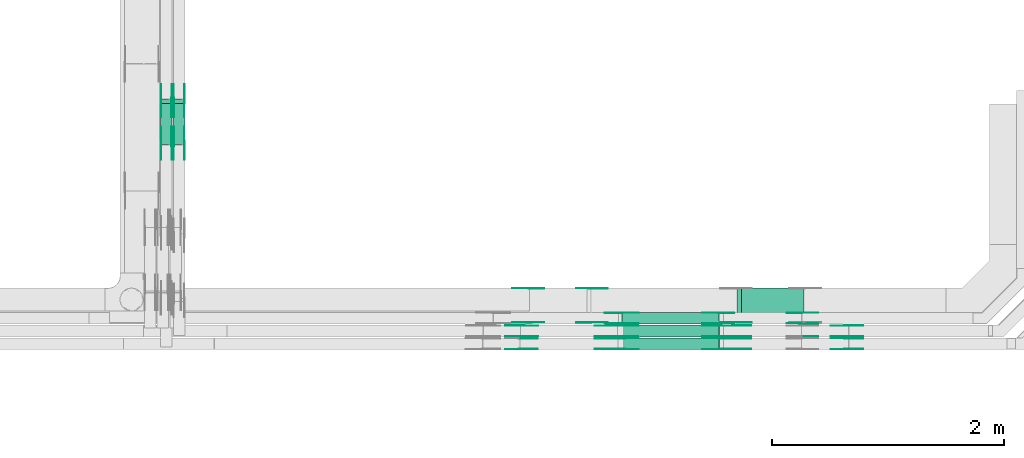
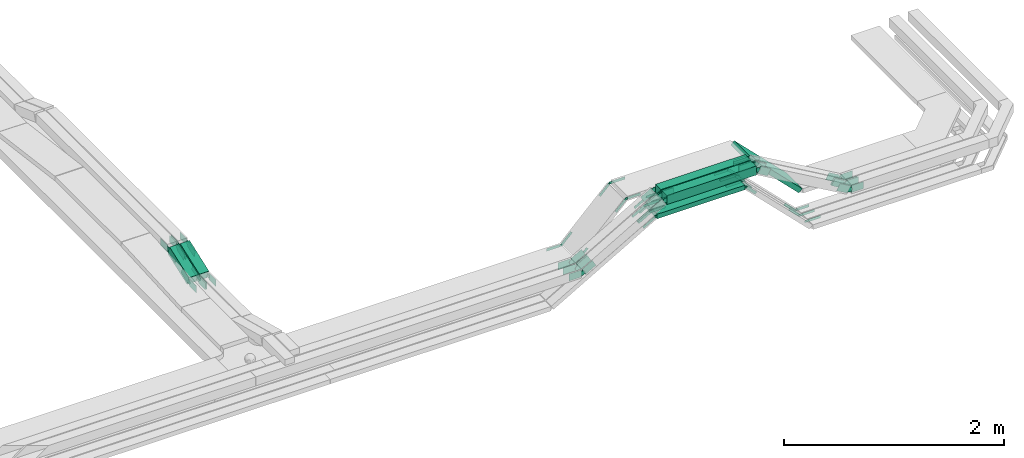
# One storey, part 26 of 33: 86 flow fittings, 8 flow segments.
"""IFC2X3 building model written with IfcOpenShell, lengths in millimetres."""

from ifc_helpers import new_model, entity, si_unit, converted_unit, derived_unit, direction, frame, frame_2d, origin, place, context, subcontext, project, spatial, polyline, circle_curve, parameter, trimmed, segment, composite_curve, rectangle, outline, extrude, source, transform, mapped, material, type_object, type_shapes, element, save


model = new_model("IFC2X3")

# Units and contexts
model_context = context("Model", 3, precision=0.01, world=origin(), true_north=direction((6.12303176911189e-17, 1.0)))
body_context = subcontext(model_context, "Body", "Model", "MODEL_VIEW")
ifc_project = project(units=[si_unit("LENGTHUNIT", "METRE", prefix="MILLI"), si_unit("AREAUNIT", "SQUARE_METRE"), si_unit("VOLUMEUNIT", "CUBIC_METRE"), converted_unit("PLANEANGLEUNIT", "DEGREE", entity("IfcRatioMeasure", 0.0174532925199433), si_unit("PLANEANGLEUNIT", "RADIAN"), dimensions=[0, 0, 0, 0, 0, 0, 0]), si_unit("MASSUNIT", "GRAM", prefix="KILO"), derived_unit("MASSDENSITYUNIT", [(si_unit("MASSUNIT", "GRAM", prefix="KILO"), 1), (si_unit("LENGTHUNIT", "METRE"), -3)]), derived_unit("MOMENTOFINERTIAUNIT", [(si_unit("LENGTHUNIT", "METRE"), 4)]), si_unit("TIMEUNIT", "SECOND"), si_unit("FREQUENCYUNIT", "HERTZ"), si_unit("THERMODYNAMICTEMPERATUREUNIT", "DEGREE_CELSIUS"), derived_unit("THERMALTRANSMITTANCEUNIT", [(si_unit("MASSUNIT", "GRAM", prefix="KILO"), 1), (si_unit("THERMODYNAMICTEMPERATUREUNIT", "KELVIN"), -1), (si_unit("TIMEUNIT", "SECOND"), -3)]), derived_unit("VOLUMETRICFLOWRATEUNIT", [(si_unit("LENGTHUNIT", "METRE"), 3), (si_unit("TIMEUNIT", "SECOND"), -1)]), derived_unit("MASSFLOWRATEUNIT", [(si_unit("MASSUNIT", "GRAM", prefix="KILO"), 1), (si_unit("TIMEUNIT", "SECOND"), -1)]), derived_unit("ROTATIONALFREQUENCYUNIT", [(si_unit("TIMEUNIT", "SECOND"), -1)]), si_unit("ELECTRICCURRENTUNIT", "AMPERE"), si_unit("ELECTRICVOLTAGEUNIT", "VOLT"), si_unit("POWERUNIT", "WATT"), si_unit("FORCEUNIT", "NEWTON", prefix="KILO"), si_unit("ILLUMINANCEUNIT", "LUX"), si_unit("LUMINOUSFLUXUNIT", "LUMEN"), si_unit("LUMINOUSINTENSITYUNIT", "CANDELA"), derived_unit("USERDEFINED", [(si_unit("MASSUNIT", "GRAM", prefix="KILO"), -1), (si_unit("LENGTHUNIT", "METRE"), -2), (si_unit("TIMEUNIT", "SECOND"), 3), (si_unit("LUMINOUSFLUXUNIT", "LUMEN"), 1)]), derived_unit("LINEARVELOCITYUNIT", [(si_unit("LENGTHUNIT", "METRE"), 1), (si_unit("TIMEUNIT", "SECOND"), -1)]), si_unit("PRESSUREUNIT", "PASCAL"), derived_unit("USERDEFINED", [(si_unit("LENGTHUNIT", "METRE"), -2), (si_unit("MASSUNIT", "GRAM", prefix="KILO"), 1), (si_unit("TIMEUNIT", "SECOND"), -2)]), derived_unit("LINEARFORCEUNIT", [(si_unit("MASSUNIT", "GRAM", prefix="KILO"), 1), (si_unit("LENGTHUNIT", "METRE"), 1), (si_unit("TIMEUNIT", "SECOND"), -2), (si_unit("LENGTHUNIT", "METRE"), -1)]), derived_unit("PLANARFORCEUNIT", [(si_unit("MASSUNIT", "GRAM", prefix="KILO"), 1), (si_unit("LENGTHUNIT", "METRE"), 1), (si_unit("TIMEUNIT", "SECOND"), -2), (si_unit("LENGTHUNIT", "METRE"), -2)])], contexts=[model_context])

# Site, building, storey
site_placement = place(None, frame((0.0, -0.00077364408347762, 0.0)))
site = spatial("IfcSite", under=ifc_project, at=site_placement, CompositionType="ELEMENT")
building_placement = place(site_placement, origin())
building = spatial("IfcBuilding", under=site, at=building_placement, CompositionType="ELEMENT")
storey_placement = place(building_placement, frame((0.0, 0.0, 8100.0)))
storey = spatial("IfcBuildingStorey", under=building, at=storey_placement, CompositionType="ELEMENT", Elevation=8100.0)

# Flow segments
cable_carrier_segment_type = type_object("IfcCableCarrierSegmentType", PredefinedType="CABLETRAYSEGMENT")
flow_segment_1_placement = place(storey_placement, frame((64598.6638560837, 8749.97860618826, 3299.3482586163)))
element("IfcFlowSegment", 1, at=flow_segment_1_placement, inside=storey, type_object=cable_carrier_segment_type, context=body_context, shape_type="SweptSolid", body=[
    extrude(rectangle(XDim=939.968624882914, YDim=99.9999999999989, at=frame_2d((4.32009983342141e-12, -5.40012479177676e-13), x_axis=(1.0, 0.0))), frame((469.984312441453, 50.0, 0.0)), (0.0, 0.0, 1.0), 99.9999999999989),
])
flow_segment_2_placement = place(storey_placement, frame((65573.517007287, 8869.97860618828, 2758.52334059706)))
element("IfcFlowSegment", 2, at=flow_segment_2_placement, inside=storey, type_object=cable_carrier_segment_type, context=body_context, shape_type="SweptSolid", body=[
    extrude(rectangle(XDim=49.9999999999911, YDim=299.999999999999, at=frame_2d((1.08002495835535e-12, -7.65609797781508e-13), x_axis=(0.0, 1.0))), frame((17.67766952966, 150.0, 559.423905174462), z_axis=(0.707106781186569, 0.0, -0.707106781186526), x_axis=(0.0, 1.0, 0.0)), (0.0, 0.0, 1.0), 766.14487381345),
])
flow_segment_3_placement = place(storey_placement, frame((64600.049492022, 8639.9800528508, 3300.14825589832)))
element("IfcFlowSegment", 3, at=flow_segment_3_placement, inside=storey, type_object=cable_carrier_segment_type, context=body_context, shape_type="SweptSolid", body=[
    extrude(rectangle(XDim=937.197353006379, YDim=100.000000000001, at=frame_2d((-4.32009983342141e-12, -5.43565192856477e-13), x_axis=(1.0, 0.0))), frame((468.598676503194, 50.0, 0.0), z_axis=(0.0, 0.0, 1.0), x_axis=(-1.0, 0.0, 0.0)), (0.0, 0.0, 1.0), 99.9999999999989),
])
flow_segment_4_placement = place(storey_placement, frame((64494.5772882702, 8639.98005285178, 3179.56852551111)))
element("IfcFlowSegment", 4, at=flow_segment_4_placement, inside=storey, type_object=cable_carrier_segment_type, context=body_context, shape_type="SweptSolid", body=[
    extrude(rectangle(XDim=920.492323280355, YDim=99.9999999979415, at=frame_2d((4.34852154285181e-12, 0.0), x_axis=(1.0, 0.0))), frame((460.2464824936, 50.0, 0.00295351838206557), z_axis=(-6.41725804195765e-06, 0.0, 1.0), x_axis=(-1.0, 0.0, -6.41725804195765e-06)), (0.0, 0.0, 1.0), 49.9999999989737),
])
flow_segment_5_placement = place(storey_placement, frame((64494.5762399243, 8749.97860620028, 3179.57026658135)))
element("IfcFlowSegment", 5, at=flow_segment_5_placement, inside=storey, type_object=cable_carrier_segment_type, context=body_context, shape_type="SweptSolid", body=[
    extrude(rectangle(XDim=920.463298114925, YDim=99.9999999758575, at=frame_2d((0.0, 5.43565192856477e-13), x_axis=(1.0, 0.0))), frame((460.233177094855, 50.0, 0.0140670022275913), z_axis=(-3.05650475309181e-05, 0.0, 1.0), x_axis=(-1.0, 0.0, -3.05650475309181e-05)), (0.0, 0.0, 1.0), 49.9999999879301),
])
flow_segment_6_placement = place(storey_placement, frame((64581.2388099734, 8859.97860618819, 3179.57296964547)))
element("IfcFlowSegment", 6, at=flow_segment_6_placement, inside=storey, type_object=cable_carrier_segment_type, context=body_context, shape_type="SweptSolid", body=[
    extrude(rectangle(XDim=833.83326858157, YDim=100.000000000001, at=frame_2d((4.34852154285181e-12, -1.08357767203415e-12), x_axis=(1.0, 0.0))), frame((416.91663429079, 50.0, 0.0), z_axis=(0.0, 0.0, 1.0), x_axis=(-1.0, 0.0, 0.0)), (0.0, 0.0, 1.0), 50.0000000000016),
])
flow_segment_7_placement = place(storey_placement, frame((60610.1085349486, 10406.1458909602, 2721.67706412327)))
element("IfcFlowSegment", 7, at=flow_segment_7_placement, inside=storey, type_object=cable_carrier_segment_type, context=body_context, shape_type="SweptSolid", body=[
    extrude(rectangle(XDim=100.000000000001, YDim=99.9999999999946, at=frame_2d((-1.389111048411e-12, 0.0), x_axis=(1.0, 0.0))), frame((50.0, 17.1010071662797, 46.9846310392979), z_axis=(0.0, 0.939692620785929, 0.342020143325613), x_axis=(0.0, -0.342020143325613, 0.939692620785929)), (0.0, 0.0, 1.0), 373.670280105796),
])
flow_segment_8_placement = place(storey_placement, frame((60720.1085349486, 10406.1343034904, 2721.70934145701)))
element("IfcFlowSegment", 8, at=flow_segment_8_placement, inside=storey, type_object=cable_carrier_segment_type, context=body_context, shape_type="SweptSolid", body=[
    extrude(rectangle(XDim=99.9999999999992, YDim=99.9999999999946, at=frame_2d((1.3926637620898e-12, 0.0), x_axis=(1.0, 0.0))), frame((50.0, 17.1010071660415, 46.9846310393846), z_axis=(0.0, 0.939692620787677, 0.34202014332081), x_axis=(0.0, -0.34202014332081, 0.939692620787677)), (0.0, 0.0, 1.0), 373.682611233208),
])

# Flow fittings
ifc_material = material(Name="G")
cable_carrier_fitting_type_1 = type_object("IfcCableCarrierFittingType", PredefinedType="NOTDEFINED", material=ifc_material)
shared_shape_1 = source(origin(), body_context, "Body", "SweptSolid", [
    extrude(outline(composite_curve([segment(trimmed(circle_curve(frame_2d((-44.5901162790698, 0.0), x_axis=(1.0, 0.0)), 12.5), [parameter(90.0000000000007)], [parameter(270.0)], True, "PARAMETER"), True, "CONTINUOUS"), segment(polyline([(-44.5901162790697, -12.5), (-33.0901162790698, -12.5)]), True, "CONTINUOUS"), segment(polyline([(-33.0901162790698, -12.5), (-31.2296511627907, -14.5)]), True, "CONTINUOUS"), segment(polyline([(-31.2296511627907, -14.5), (108.90988372093, -14.5)]), True, "CONTINUOUS"), segment(polyline([(108.90988372093, -14.5), (108.90988372093, 14.5)]), True, "CONTINUOUS"), segment(polyline([(108.90988372093, 14.5), (-31.2296511627907, 14.5)]), True, "CONTINUOUS"), segment(polyline([(-31.2296511627907, 14.5), (-33.0901162790698, 12.5)]), True, "CONTINUOUS"), segment(polyline([(-33.0901162790698, 12.5), (-44.5901162790699, 12.5)]), True, "CONTINUOUS")], self_intersect=False)), frame((44.5901162790698, 0.0, 0.0), z_axis=(0.0, 0.0, -1.0), x_axis=(1.0, 0.0, 0.0)), (0.0, 0.0, -1.0), 2.0),
])
type_shapes(cable_carrier_fitting_type_1, [shared_shape_1])
for number, where, z_axis, x_axis in (
    (9, (65428.0842718638, 8864.51860617803, 3204.57296964563), (0.0, -1.0, 0.0), (-1.0, 0.0, 0.0)),
    (10, (64572.468283393, 8955.43860619837, 3204.57296964544), (0.0, 1.0, 0.0), (1.0, 0.0, 0.0)),
    (11, (65428.056087985, 8754.51860617804, 3204.60115352443), (0.0, -1.0, 0.0), (-0.999999977631966, 0.0, -0.000211509025242751)),
    (12, (64485.8072939881, 8845.43860619837, 3204.56980581165), (0.0, 1.0, 0.0), (1.0, 0.0, 5.25390230209366e-05)),
    (13, (65428.0824430117, 8644.5200528406, 3204.57479849771), (0.0, -1.0, 0.0), (-1.0, 0.0, -2.81226541815616e-05)),
    (14, (64485.8070628246, 8735.44005286093, 3204.56844610609), (0.0, 1.0, 0.0), (1.0, 0.0, 9.05365043246675e-06)),
    (15, (64306.0839455148, 8874.5186061781, 3327.14825589831), (0.0, -1.0, 0.0), (-0.707106781186591, 0.0, -0.707106781186504)),
    (16, (66118.4572387915, 8864.51860617804, 2514.20000271793), (0.0, -1.0, 0.0), (1.0, 0.0, 0.0)),
    (17, (66118.4572387915, 8754.51860617805, 2514.20000271791), (0.0, -1.0, 0.0), (1.0, 0.0, 0.0)),
    (18, (63792.8554852921, 9165.43860619843, 2813.91979567562), (0.0, 1.0, 0.0), (-1.0, 0.0, 0.0)),
):
    element("IfcFlowFitting", number, at=place(storey_placement, frame(where, z_axis=z_axis, x_axis=x_axis)), inside=storey, type_object=cable_carrier_fitting_type_1, material=ifc_material, context=body_context, shape_type="MappedRepresentation", body=[
        mapped(shared_shape_1, transform((0.0, 0.0, 0.0), scale=1.0)),
    ])
cable_carrier_fitting_type_2 = type_object("IfcCableCarrierFittingType", PredefinedType="NOTDEFINED", material=ifc_material)
shared_shape_2 = source(origin(), body_context, "Body", "SweptSolid", [
    extrude(outline(composite_curve([segment(trimmed(circle_curve(frame_2d((-44.5901162790697, 0.0), x_axis=(1.0, 0.0)), 12.5), [parameter(90.0000000000007)], [parameter(270.0)], True, "PARAMETER"), True, "CONTINUOUS"), segment(polyline([(-44.5901162790697, -12.5), (-33.0901162790697, -12.5)]), True, "CONTINUOUS"), segment(polyline([(-33.0901162790697, -12.5), (-31.2296511627907, -14.5)]), True, "CONTINUOUS"), segment(polyline([(-31.2296511627907, -14.5), (108.90988372093, -14.5)]), True, "CONTINUOUS"), segment(polyline([(108.90988372093, -14.5), (108.90988372093, 14.5)]), True, "CONTINUOUS"), segment(polyline([(108.90988372093, 14.5), (-31.2296511627907, 14.5)]), True, "CONTINUOUS"), segment(polyline([(-31.2296511627907, 14.5), (-33.0901162790698, 12.5)]), True, "CONTINUOUS"), segment(polyline([(-33.0901162790698, 12.5), (-44.5901162790699, 12.5)]), True, "CONTINUOUS")], self_intersect=False)), frame((44.5901162790697, 0.0, 0.0)), (0.0, 0.0, 1.0), 2.0),
])
type_shapes(cable_carrier_fitting_type_2, [shared_shape_2])
for number, where, z_axis, x_axis in (
    (19, (65428.0842718639, 8955.43860619835, 3204.57296964563), (0.0, 1.0, 0.0), (-1.0, 0.0, 0.0)),
    (20, (64572.468283393, 8864.51860617805, 3204.57296964544), (0.0, -1.0, 0.0), (1.0, 0.0, 0.0)),
    (21, (65428.056087985, 8845.43860619836, 3204.60115352443), (0.0, 1.0, 0.0), (-0.999999977631966, 0.0, -0.000211509025242751)),
    (22, (64485.8072939881, 8754.51860617806, 3204.56980581165), (0.0, -1.0, 0.0), (1.0, 0.0, 5.25390230209366e-05)),
    (23, (65428.0824430117, 8735.44005286091, 3204.57479849771), (0.0, 1.0, 0.0), (-1.0, 0.0, -2.81226541815616e-05)),
    (24, (64485.8070628246, 8644.52005284061, 3204.56844610609), (0.0, -1.0, 0.0), (1.0, 0.0, 9.05365043246675e-06)),
    (25, (64306.0839455148, 9165.43860619842, 3327.14825589831), (0.0, 1.0, 0.0), (-0.707106781186591, 0.0, -0.707106781186504)),
    (26, (65581.9936666899, 8874.51860617812, 3327.14825589831), (0.0, -1.0, 0.0), (0.707106781186591, 0.0, -0.707106781186504)),
    (27, (66118.4572387915, 8955.43860619836, 2514.20000271793), (0.0, 1.0, 0.0), (1.0, 0.0, 0.0)),
    (28, (63792.8554852921, 8874.51860617811, 2813.91979567562), (0.0, -1.0, 0.0), (-1.0, 0.0, 0.0)),
):
    element("IfcFlowFitting", number, at=place(storey_placement, frame(where, z_axis=z_axis, x_axis=x_axis)), inside=storey, type_object=cable_carrier_fitting_type_2, material=ifc_material, context=body_context, shape_type="MappedRepresentation", body=[
        mapped(shared_shape_2, transform((0.0, 0.0, 0.0), scale=1.0)),
    ])
cable_carrier_fitting_type_3 = type_object("IfcCableCarrierFittingType", PredefinedType="NOTDEFINED", material=ifc_material)
shared_shape_3 = source(origin(), body_context, "Body", "SweptSolid", [
    extrude(outline(composite_curve([segment(trimmed(circle_curve(frame_2d((-44.5901162790698, 0.0), x_axis=(1.0, 0.0)), 12.5), [parameter(90.0000000000007)], [parameter(270.0)], True, "PARAMETER"), True, "CONTINUOUS"), segment(polyline([(-44.5901162790697, -12.5), (-33.0901162790698, -12.5)]), True, "CONTINUOUS"), segment(polyline([(-33.0901162790698, -12.5), (-31.2296511627907, -14.5)]), True, "CONTINUOUS"), segment(polyline([(-31.2296511627907, -14.5), (108.90988372093, -14.5)]), True, "CONTINUOUS"), segment(polyline([(108.90988372093, -14.5), (108.90988372093, 14.5)]), True, "CONTINUOUS"), segment(polyline([(108.90988372093, 14.5), (-31.2296511627907, 14.5)]), True, "CONTINUOUS"), segment(polyline([(-31.2296511627907, 14.5), (-33.0901162790698, 12.5)]), True, "CONTINUOUS"), segment(polyline([(-33.0901162790698, 12.5), (-44.5901162790699, 12.5)]), True, "CONTINUOUS")], self_intersect=False)), frame((44.5901162790698, 0.0, 0.0), z_axis=(0.0, 0.0, -1.0), x_axis=(1.0, 0.0, 0.0)), (0.0, 0.0, -1.0), 2.0),
])
type_shapes(cable_carrier_fitting_type_3, [shared_shape_3])
for number, where, z_axis, x_axis in (
    (29, (65428.0842718638, 8953.43860619835, 3204.57296964563), (0.0, 1.0, 0.0), (0.707106781186533, 0.0, -0.707106781186562)),
    (30, (64572.468283393, 8866.51860617805, 3204.57296964544), (0.0, -1.0, 0.0), (-0.866025403784435, 0.0, -0.500000000000006)),
    (31, (65428.056087985, 8843.43860619836, 3204.60115352443), (0.0, 1.0, 0.0), (0.707106781186527, 0.0, -0.707106781186568)),
    (32, (64485.8072939881, 8756.51860617806, 3204.56980581165), (0.0, -1.0, 0.0), (-0.866025403784419, 0.0, -0.500000000000034)),
    (33, (65428.0824430117, 8733.44005286091, 3204.57479849771), (0.0, 1.0, 0.0), (0.707106781186496, 0.0, -0.707106781186599)),
    (34, (64485.8070628246, 8646.52005284061, 3204.56844610609), (0.0, -1.0, 0.0), (-0.866025403784408, 0.0, -0.500000000000054)),
    (35, (64306.0839455148, 9163.43860619842, 3327.14825589831), (0.0, 1.0, 0.0), (1.0, 0.0, 0.0)),
    (36, (65581.9936666899, 8876.51860617812, 3327.14825589831), (0.0, -1.0, 0.0), (-1.0, 0.0, 0.0)),
    (37, (66118.4572387915, 8953.43860619836, 2514.20000271793), (0.0, 1.0, 0.0), (-0.707106781186547, 0.0, 0.707106781186548)),
    (38, (63792.8554852921, 8876.51860617811, 2813.91979567562), (0.0, -1.0, 0.0), (0.70710678118647, 0.0, 0.707106781186625)),
):
    element("IfcFlowFitting", number, at=place(storey_placement, frame(where, z_axis=z_axis, x_axis=x_axis)), inside=storey, type_object=cable_carrier_fitting_type_3, material=ifc_material, context=body_context, shape_type="MappedRepresentation", body=[
        mapped(shared_shape_3, transform((0.0, 0.0, 0.0), scale=1.0)),
    ])
cable_carrier_fitting_type_4 = type_object("IfcCableCarrierFittingType", PredefinedType="NOTDEFINED", material=ifc_material)
shared_shape_4 = source(origin(), body_context, "Body", "SweptSolid", [
    extrude(outline(composite_curve([segment(trimmed(circle_curve(frame_2d((-44.5901162790697, 0.0), x_axis=(1.0, 0.0)), 12.5), [parameter(90.0000000000007)], [parameter(270.0)], True, "PARAMETER"), True, "CONTINUOUS"), segment(polyline([(-44.5901162790697, -12.5), (-33.0901162790697, -12.5)]), True, "CONTINUOUS"), segment(polyline([(-33.0901162790697, -12.5), (-31.2296511627907, -14.5)]), True, "CONTINUOUS"), segment(polyline([(-31.2296511627907, -14.5), (108.90988372093, -14.5)]), True, "CONTINUOUS"), segment(polyline([(108.90988372093, -14.5), (108.90988372093, 14.5)]), True, "CONTINUOUS"), segment(polyline([(108.90988372093, 14.5), (-31.2296511627907, 14.5)]), True, "CONTINUOUS"), segment(polyline([(-31.2296511627907, 14.5), (-33.0901162790698, 12.5)]), True, "CONTINUOUS"), segment(polyline([(-33.0901162790698, 12.5), (-44.5901162790699, 12.5)]), True, "CONTINUOUS")], self_intersect=False)), frame((44.5901162790697, 0.0, 0.0)), (0.0, 0.0, 1.0), 2.0),
])
type_shapes(cable_carrier_fitting_type_4, [shared_shape_4])
for number, where, z_axis, x_axis in (
    (39, (65428.0842718638, 8866.51860617804, 3204.57296964563), (0.0, -1.0, 0.0), (0.707106781186533, 0.0, -0.707106781186562)),
    (40, (64572.468283393, 8953.43860619836, 3204.57296964544), (0.0, 1.0, 0.0), (-0.866025403784435, 0.0, -0.500000000000006)),
    (41, (65428.056087985, 8756.51860617805, 3204.60115352443), (0.0, -1.0, 0.0), (0.707106781186527, 0.0, -0.707106781186568)),
    (42, (64485.8072939881, 8843.43860619837, 3204.56980581165), (0.0, 1.0, 0.0), (-0.866025403784419, 0.0, -0.500000000000034)),
    (43, (65428.0824430117, 8646.5200528406, 3204.57479849771), (0.0, -1.0, 0.0), (0.707106781186496, 0.0, -0.707106781186599)),
    (44, (64485.8070628246, 8733.44005286093, 3204.56844610609), (0.0, 1.0, 0.0), (-0.866025403784408, 0.0, -0.500000000000054)),
    (45, (64306.0839455148, 8876.51860617811, 3327.14825589831), (0.0, -1.0, 0.0), (1.0, 0.0, 0.0)),
    (46, (66118.4572387915, 8866.51860617804, 2514.20000271793), (0.0, -1.0, 0.0), (-0.707106781186547, 0.0, 0.707106781186548)),
    (47, (63792.8554852921, 9163.43860619842, 2813.91979567562), (0.0, 1.0, 0.0), (0.70710678118647, 0.0, 0.707106781186625)),
):
    element("IfcFlowFitting", number, at=place(storey_placement, frame(where, z_axis=z_axis, x_axis=x_axis)), inside=storey, type_object=cable_carrier_fitting_type_4, material=ifc_material, context=body_context, shape_type="MappedRepresentation", body=[
        mapped(shared_shape_4, transform((0.0, 0.0, 0.0), scale=1.0)),
    ])
cable_carrier_fitting_type_5 = type_object("IfcCableCarrierFittingType", PredefinedType="NOTDEFINED", material=ifc_material)
shared_shape_5 = source(origin(), body_context, "Body", "SweptSolid", [
    extrude(outline(composite_curve([segment(trimmed(circle_curve(frame_2d((-41.4651162790697, 0.0), x_axis=(1.0, 0.0)), 25.0), [parameter(90.0000000000007)], [parameter(270.0)], True, "PARAMETER"), True, "CONTINUOUS"), segment(polyline([(-41.4651162790697, -25.0), (-29.9651162790697, -25.0)]), True, "CONTINUOUS"), segment(polyline([(-29.9651162790697, -25.0), (-28.1046511627907, -38.5)]), True, "CONTINUOUS"), segment(polyline([(-28.1046511627907, -38.5), (99.5348837209303, -38.5)]), True, "CONTINUOUS"), segment(polyline([(99.5348837209303, -38.5), (99.5348837209303, 38.5)]), True, "CONTINUOUS"), segment(polyline([(99.5348837209303, 38.5), (-28.1046511627907, 38.5)]), True, "CONTINUOUS"), segment(polyline([(-28.1046511627907, 38.5), (-29.9651162790697, 25.0)]), True, "CONTINUOUS"), segment(polyline([(-29.9651162790697, 25.0), (-41.46511627907, 25.0)]), True, "CONTINUOUS")], self_intersect=False)), frame((41.4651162790697, 0.0, 0.0), z_axis=(0.0, 0.0, -1.0), x_axis=(1.0, 0.0, 0.0)), (0.0, 0.0, -1.0), 2.0),
])
type_shapes(cable_carrier_fitting_type_5, [shared_shape_5])
for number, where, z_axis, x_axis in (
    (48, (60614.6485349384, 10784.269226351, 2900.06307654177), (-1.0, 0.0, 0.0), (0.0, 1.0, 0.0)),
    (49, (60614.6485349384, 10413.3597747243, 2765.06307654165), (-1.0, 0.0, 0.0), (0.0, -1.0, 0.0)),
    (50, (60724.6485349384, 10784.2692263511, 2900.09957136772), (-1.0, 0.0, 0.0), (0.0, 1.0, 0.0)),
    (51, (60724.6485349384, 10413.3480455124, 2765.09530228571), (-1.0, 0.0, 0.0), (0.0, -1.0, 5.41816061694345e-06)),
    (52, (66519.4572387913, 8735.44005286096, 2792.0), (0.0, 1.0, 0.0), (-0.866025403786882, 0.0, 0.499999999995767)),
    (53, (64583.1945996926, 8754.5186061781, 3349.34825861631), (0.0, -1.0, 0.0), (-0.866025403786882, 0.0, -0.499999999995767)),
    (54, (65554.1017373577, 8845.43860619842, 3349.34825861632), (0.0, 1.0, 0.0), (0.866025403786882, 0.0, -0.499999999995767)),
    (55, (65552.7161014195, 8644.52005284064, 3350.14825589826), (0.0, -1.0, 0.0), (-1.0, 0.0, 0.0)),
    (56, (64584.5802356308, 8735.44005286097, 3350.14825589826), (0.0, 1.0, 0.0), (1.0, 0.0, 0.0)),
    (57, (63718.3187030844, 8845.43860610517, 2850.01192689393), (0.0, 1.0, 0.0), (-1.0, 0.0, 8.83735248702333e-07)),
    (58, (66519.4572387913, 8754.5186061781, 2792.0), (0.0, -1.0, 0.0), (1.0, 0.0, 0.0)),
):
    element("IfcFlowFitting", number, at=place(storey_placement, frame(where, z_axis=z_axis, x_axis=x_axis)), inside=storey, type_object=cable_carrier_fitting_type_5, material=ifc_material, context=body_context, shape_type="MappedRepresentation", body=[
        mapped(shared_shape_5, transform((0.0, 0.0, 0.0), scale=1.0)),
    ])
cable_carrier_fitting_type_6 = type_object("IfcCableCarrierFittingType", PredefinedType="NOTDEFINED", material=ifc_material)
shared_shape_6 = source(origin(), body_context, "Body", "SweptSolid", [
    extrude(outline(composite_curve([segment(trimmed(circle_curve(frame_2d((-41.4651162790697, 0.0), x_axis=(1.0, 0.0)), 25.0), [parameter(90.0000000000007)], [parameter(270.0)], True, "PARAMETER"), True, "CONTINUOUS"), segment(polyline([(-41.4651162790697, -25.0), (-29.9651162790697, -25.0)]), True, "CONTINUOUS"), segment(polyline([(-29.9651162790697, -25.0), (-28.1046511627907, -38.5)]), True, "CONTINUOUS"), segment(polyline([(-28.1046511627907, -38.5), (99.5348837209303, -38.5)]), True, "CONTINUOUS"), segment(polyline([(99.5348837209303, -38.5), (99.5348837209303, 38.5)]), True, "CONTINUOUS"), segment(polyline([(99.5348837209303, 38.5), (-28.1046511627907, 38.5)]), True, "CONTINUOUS"), segment(polyline([(-28.1046511627907, 38.5), (-29.9651162790697, 25.0)]), True, "CONTINUOUS"), segment(polyline([(-29.9651162790697, 25.0), (-41.46511627907, 25.0)]), True, "CONTINUOUS")], self_intersect=False)), frame((41.4651162790697, 0.0, 0.0)), (0.0, 0.0, 1.0), 2.0),
])
type_shapes(cable_carrier_fitting_type_6, [shared_shape_6])
for number, where, z_axis, x_axis in (
    (59, (60705.5685349588, 10784.269226351, 2900.06307654177), (1.0, 0.0, 0.0), (0.0, 1.0, 0.0)),
    (60, (60705.5685349588, 10413.3597747243, 2765.06307654165), (1.0, 0.0, 0.0), (0.0, -1.0, 0.0)),
    (61, (60815.5685349588, 10784.2692263511, 2900.09957136772), (1.0, 0.0, 0.0), (0.0, 1.0, 0.0)),
    (62, (60815.5685349588, 10413.3480455124, 2765.09530228571), (1.0, 0.0, 0.0), (0.0, -1.0, 5.41816061694345e-06)),
    (63, (63717.4196649966, 8644.51859021176, 2849.49286701191), (0.0, -1.0, 0.0), (-1.0, 0.0, 0.0)),
    (64, (66519.4572387913, 8644.52005284064, 2792.0), (0.0, -1.0, 0.0), (-0.866025403786882, 0.0, 0.499999999995767)),
    (65, (64583.1945996926, 8845.43860619842, 3349.34825861632), (0.0, 1.0, 0.0), (-0.866025403786882, 0.0, -0.499999999995767)),
    (66, (65554.1017373577, 8754.5186061781, 3349.34825861632), (0.0, -1.0, 0.0), (0.866025403786882, 0.0, -0.499999999995767)),
    (67, (65552.7161014195, 8735.44005286096, 3350.14825589826), (0.0, 1.0, 0.0), (-1.0, 0.0, 0.0)),
    (68, (64584.5802356308, 8644.52005284065, 3350.14825589826), (0.0, -1.0, 0.0), (1.0, 0.0, 0.0)),
    (69, (63718.3187030844, 8754.51860608485, 2850.01192689393), (0.0, -1.0, 0.0), (-1.0, 0.0, 8.83735248702333e-07)),
    (70, (66519.4572387913, 8845.43860619842, 2792.0), (0.0, 1.0, 0.0), (1.0, 0.0, 0.0)),
):
    element("IfcFlowFitting", number, at=place(storey_placement, frame(where, z_axis=z_axis, x_axis=x_axis)), inside=storey, type_object=cable_carrier_fitting_type_6, material=ifc_material, context=body_context, shape_type="MappedRepresentation", body=[
        mapped(shared_shape_6, transform((0.0, 0.0, 0.0), scale=1.0)),
    ])
cable_carrier_fitting_type_7 = type_object("IfcCableCarrierFittingType", PredefinedType="NOTDEFINED", material=ifc_material)
shared_shape_7 = source(origin(), body_context, "Body", "SweptSolid", [
    extrude(outline(composite_curve([segment(trimmed(circle_curve(frame_2d((-41.4651162790697, 0.0), x_axis=(1.0, 0.0)), 25.0), [parameter(90.0000000000007)], [parameter(270.0)], True, "PARAMETER"), True, "CONTINUOUS"), segment(polyline([(-41.4651162790697, -25.0), (-29.9651162790697, -25.0)]), True, "CONTINUOUS"), segment(polyline([(-29.9651162790697, -25.0), (-28.1046511627907, -38.5)]), True, "CONTINUOUS"), segment(polyline([(-28.1046511627907, -38.5), (99.5348837209303, -38.5)]), True, "CONTINUOUS"), segment(polyline([(99.5348837209303, -38.5), (99.5348837209303, 38.5)]), True, "CONTINUOUS"), segment(polyline([(99.5348837209303, 38.5), (-28.1046511627907, 38.5)]), True, "CONTINUOUS"), segment(polyline([(-28.1046511627907, 38.5), (-29.9651162790697, 25.0)]), True, "CONTINUOUS"), segment(polyline([(-29.9651162790697, 25.0), (-41.46511627907, 25.0)]), True, "CONTINUOUS")], self_intersect=False)), frame((41.4651162790697, 0.0, 0.0), z_axis=(0.0, 0.0, -1.0), x_axis=(1.0, 0.0, 0.0)), (0.0, 0.0, -1.0), 2.0),
])
type_shapes(cable_carrier_fitting_type_7, [shared_shape_7])
for number, where, z_axis, x_axis in (
    (71, (60703.5685349588, 10784.269226351, 2900.06307654177), (1.0, 0.0, 0.0), (0.0, -0.939692620785937, -0.342020143325589)),
    (72, (60703.5685349588, 10413.3597747243, 2765.06307654165), (1.0, 0.0, 0.0), (0.0, 0.93969262078593, 0.34202014332561)),
    (73, (60813.5685349588, 10784.2692263511, 2900.09957136772), (1.0, 0.0, 0.0), (0.0, -0.939692620787653, -0.342020143320874)),
    (74, (60813.5685349588, 10413.3480455124, 2765.09530228571), (1.0, 0.0, 0.0), (0.0, 0.939692620787683, 0.342020143320792)),
    (75, (63717.4196649965, 8646.51859021176, 2849.49286701191), (0.0, -1.0, 0.0), (0.866025403784424, 0.0, 0.500000000000026)),
    (76, (66519.4572387913, 8646.52005284064, 2792.0), (0.0, -1.0, 0.0), (1.0, 0.0, 0.0)),
    (77, (64583.1945996926, 8843.43860619842, 3349.34825861631), (0.0, 1.0, 0.0), (1.0, 0.0, 0.0)),
    (78, (65554.1017373577, 8756.5186061781, 3349.34825861631), (0.0, -1.0, 0.0), (-1.0, 0.0, 0.0)),
    (79, (65552.7161014195, 8733.44005286096, 3350.14825589826), (0.0, 1.0, 0.0), (0.866025403784436, 0.0, -0.500000000000005)),
    (80, (64584.5802356308, 8646.52005284065, 3350.14825589826), (0.0, -1.0, 0.0), (-0.866025403784441, 0.0, -0.499999999999995)),
    (81, (63718.3187030844, 8756.51860608485, 2850.01192689393), (0.0, -1.0, 0.0), (0.866025403784432, 0.0, 0.500000000000012)),
    (82, (66519.4572387913, 8843.43860619842, 2792.0), (0.0, 1.0, 0.0), (-0.866025403784435, 0.0, 0.500000000000007)),
):
    element("IfcFlowFitting", number, at=place(storey_placement, frame(where, z_axis=z_axis, x_axis=x_axis)), inside=storey, type_object=cable_carrier_fitting_type_7, material=ifc_material, context=body_context, shape_type="MappedRepresentation", body=[
        mapped(shared_shape_7, transform((0.0, 0.0, 0.0), scale=1.0)),
    ])
cable_carrier_fitting_type_8 = type_object("IfcCableCarrierFittingType", PredefinedType="NOTDEFINED", material=ifc_material)
shared_shape_8 = source(origin(), body_context, "Body", "SweptSolid", [
    extrude(outline(composite_curve([segment(trimmed(circle_curve(frame_2d((-41.4651162790697, 0.0), x_axis=(1.0, 0.0)), 25.0), [parameter(90.0000000000007)], [parameter(270.0)], True, "PARAMETER"), True, "CONTINUOUS"), segment(polyline([(-41.4651162790697, -25.0), (-29.9651162790697, -25.0)]), True, "CONTINUOUS"), segment(polyline([(-29.9651162790697, -25.0), (-28.1046511627907, -38.5)]), True, "CONTINUOUS"), segment(polyline([(-28.1046511627907, -38.5), (99.5348837209303, -38.5)]), True, "CONTINUOUS"), segment(polyline([(99.5348837209303, -38.5), (99.5348837209303, 38.5)]), True, "CONTINUOUS"), segment(polyline([(99.5348837209303, 38.5), (-28.1046511627907, 38.5)]), True, "CONTINUOUS"), segment(polyline([(-28.1046511627907, 38.5), (-29.9651162790697, 25.0)]), True, "CONTINUOUS"), segment(polyline([(-29.9651162790697, 25.0), (-41.46511627907, 25.0)]), True, "CONTINUOUS")], self_intersect=False)), frame((41.4651162790697, 0.0, 0.0)), (0.0, 0.0, 1.0), 2.0),
])
type_shapes(cable_carrier_fitting_type_8, [shared_shape_8])
for number, where, z_axis, x_axis in (
    (83, (60616.6485349384, 10784.269226351, 2900.06307654177), (-1.0, 0.0, 0.0), (0.0, -0.939692620785937, -0.342020143325589)),
    (84, (60616.6485349384, 10413.3597747243, 2765.06307654165), (-1.0, 0.0, 0.0), (0.0, 0.93969262078593, 0.34202014332561)),
    (85, (60726.6485349384, 10784.2692263511, 2900.09957136772), (-1.0, 0.0, 0.0), (0.0, -0.939692620787653, -0.342020143320874)),
    (86, (60726.6485349384, 10413.3480455124, 2765.09530228571), (-1.0, 0.0, 0.0), (0.0, 0.939692620787683, 0.342020143320792)),
    (87, (63717.4196649965, 8733.43859023208, 2849.49286701191), (0.0, 1.0, 0.0), (0.866025403784424, 0.0, 0.500000000000026)),
    (88, (66519.4572387913, 8733.44005286096, 2792.0), (0.0, 1.0, 0.0), (1.0, 0.0, 0.0)),
    (89, (64583.1945996926, 8756.5186061781, 3349.34825861631), (0.0, -1.0, 0.0), (1.0, 0.0, 0.0)),
    (90, (65554.1017373577, 8843.43860619842, 3349.34825861631), (0.0, 1.0, 0.0), (-1.0, 0.0, 0.0)),
    (91, (65552.7161014195, 8646.52005284064, 3350.14825589826), (0.0, -1.0, 0.0), (0.866025403784436, 0.0, -0.500000000000005)),
    (92, (64584.5802356308, 8733.44005286097, 3350.14825589826), (0.0, 1.0, 0.0), (-0.866025403784441, 0.0, -0.499999999999995)),
    (93, (63718.3187030844, 8843.43860610517, 2850.01192689393), (0.0, 1.0, 0.0), (0.866025403784432, 0.0, 0.500000000000012)),
    (94, (66519.4572387913, 8756.5186061781, 2792.0), (0.0, -1.0, 0.0), (-0.866025403784435, 0.0, 0.500000000000007)),
):
    element("IfcFlowFitting", number, at=place(storey_placement, frame(where, z_axis=z_axis, x_axis=x_axis)), inside=storey, type_object=cable_carrier_fitting_type_8, material=ifc_material, context=body_context, shape_type="MappedRepresentation", body=[
        mapped(shared_shape_8, transform((0.0, 0.0, 0.0), scale=1.0)),
    ])

save(model, "model.ifc")
